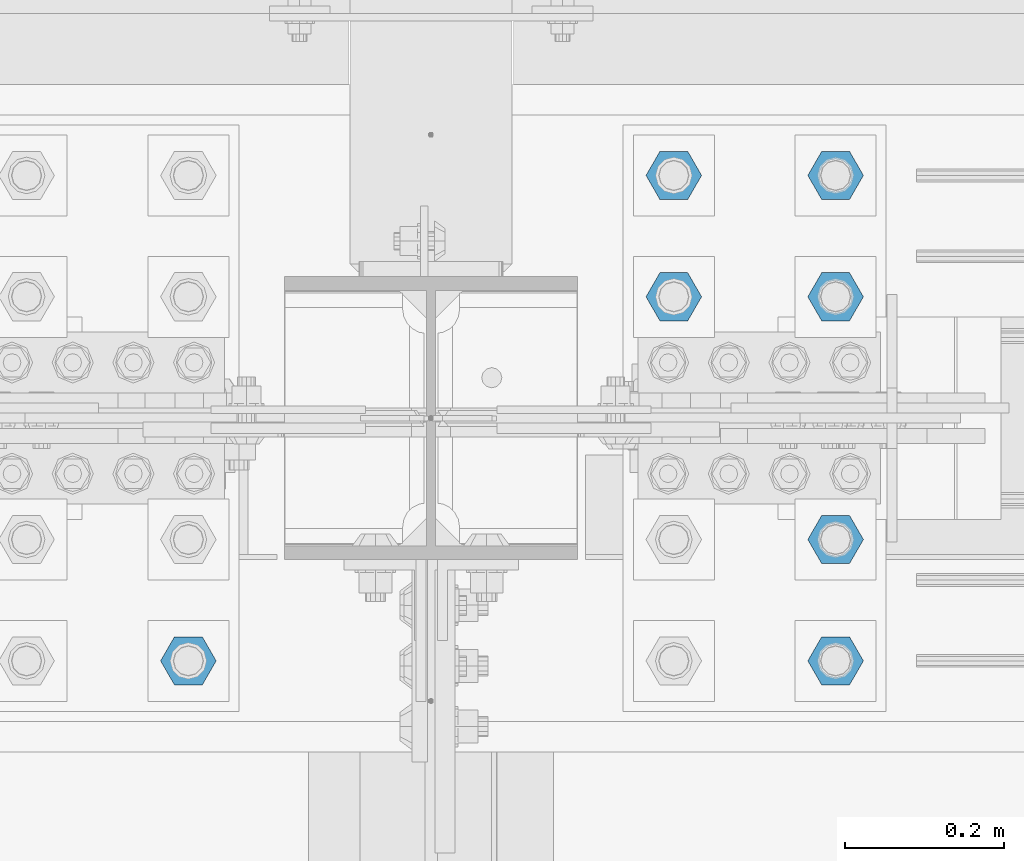
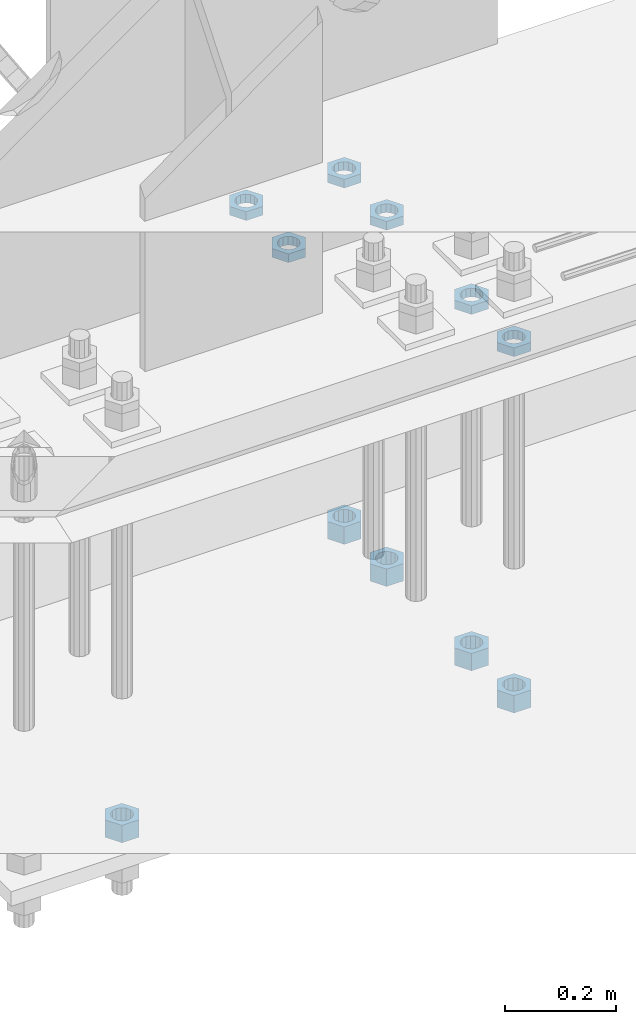
# One storey, part 2886 of 3843: 11 beams, 1 element without a shape of its own.
"""IFC2X3 building model written with IfcOpenShell, lengths in millimetres."""

from ifc_helpers import new_model, si_unit, frame, origin_with_axes, place, context, subcontext, project, spatial, faceted_brep, material, type_object, element, aggregate, save


model = new_model("IFC2X3")

# Units and contexts
model_context = context("Model", 3, precision=1e-05, world=origin_with_axes())
body_context = subcontext(model_context, "Body", "Model", "MODEL_VIEW")
ifc_project = project(units=[si_unit("LENGTHUNIT", "METRE", prefix="MILLI"), si_unit("AREAUNIT", "SQUARE_METRE"), si_unit("VOLUMEUNIT", "CUBIC_METRE"), si_unit("MASSUNIT", "GRAM", prefix="KILO"), si_unit("TIMEUNIT", "SECOND"), si_unit("PLANEANGLEUNIT", "RADIAN"), si_unit("SOLIDANGLEUNIT", "STERADIAN"), si_unit("THERMODYNAMICTEMPERATUREUNIT", "DEGREE_CELSIUS"), si_unit("LUMINOUSINTENSITYUNIT", "LUMEN")], contexts=[model_context])

# Site, building, storey
site_placement = place(None, origin_with_axes())
site = spatial("IfcSite", under=ifc_project, at=site_placement, CompositionType="ELEMENT")
building_placement = place(site_placement, origin_with_axes())
building = spatial("IfcBuilding", under=site, at=building_placement, Name="Undefined", CompositionType="ELEMENT")
storey_placement = place(building_placement, origin_with_axes())
storey = spatial("IfcBuildingStorey", under=building, at=storey_placement, Name="Undefined", CompositionType="ELEMENT", Elevation=0.0)

# Assembly, beams
assembly_placement = place(storey_placement, origin_with_axes())
assembly = element("IfcElementAssembly", 1, at=assembly_placement, inside=storey, Name="TEMPLATE", AssemblyPlace="NOTDEFINED", PredefinedType="RIGID_FRAME")
ifc_material = material(Name="STEEL/A572-50")
beam_type_1 = type_object("IfcBeamType", Name="1-1/2_HEAVY_HEX_NUT", PredefinedType="NOTDEFINED")
beam_1_placement = place(assembly_placement, frame((56438.8, 92519.5, 29298.9), z_axis=(0.0, 1.0, 0.0), x_axis=(0.0, 0.0, -1.0)))
beam_1 = element("IfcBeam", 2, at=beam_1_placement, type_object=beam_type_1, material=ifc_material, Name="NUT", ObjectType="1-1/2_HEAVY_HEX_NUT", context=body_context, shape_type="Brep", body=[
    faceted_brep([(0.0, -34.9199981689453, 0.0), (0.0, -17.4599990844727, -30.25), (38.0999999999985, -17.4599990844727, -30.25), (38.0999999999985, -34.9199981689453, 0.0), (0.0, 17.4599990844727, -30.25), (38.0999999999985, 17.4599990844727, -30.25), (0.0, 34.9199981689453, 0.0), (38.0999999999985, 34.9199981689453, 0.0), (0.0, 17.4599990844727, 30.25), (38.0999999999985, 17.4599990844727, 30.25), (0.0, -17.4599990844727, 30.25), (38.0999999999985, -17.4599990844727, 30.25), (0.0, 0.0, 20.6399993896484), (0.0, 8.9553601105581, 18.5959968835959), (38.0999999999985, 8.9553601105581, 18.5959968835959), (38.0999999999985, 0.0, 20.6399993896484), (0.0, 16.1370013209525, 12.8688291298167), (38.0999999999985, 16.1370013209525, 12.8688291298167), (0.0, 20.1225115123816, 4.59283194104501), (38.0999999999985, 20.1225115123816, 4.59283194104501), (0.0, 20.1225115123816, -4.59283194104501), (38.0999999999985, 20.1225115123816, -4.59283194104501), (0.0, 16.1370013209525, -12.8688291298167), (38.0999999999985, 16.1370013209525, -12.8688291298167), (0.0, 8.9553601105581, -18.5959968835959), (38.0999999999985, 8.9553601105581, -18.5959968835959), (0.0, 0.0, -20.6399993896484), (38.0999999999985, 0.0, -20.6399993896484), (0.0, -8.9553601105581, -18.5959968835959), (38.0999999999985, -8.9553601105581, -18.5959968835959), (0.0, -16.1370013209525, -12.8688291298167), (38.0999999999985, -16.1370013209525, -12.8688291298167), (0.0, -20.1225115123816, -4.59283194104501), (38.0999999999985, -20.1225115123816, -4.59283194104501), (0.0, -20.1225115123816, 4.59283194104501), (38.0999999999985, -20.1225115123816, 4.59283194104501), (0.0, -16.1370013209525, 12.8688291298167), (38.0999999999985, -16.1370013209525, 12.8688291298167), (0.0, -8.9553601105581, 18.5959968835959), (38.0999999999985, -8.9553601105581, 18.5959968835959)], [[[0, 1, 2, 3]], [[1, 4, 5, 2]], [[4, 6, 7, 5]], [[6, 8, 9, 7]], [[8, 10, 11, 9]], [[10, 0, 3, 11]], [[12, 13, 14, 15]], [[13, 16, 17, 14]], [[16, 18, 19, 17]], [[18, 20, 21, 19]], [[20, 22, 23, 21]], [[22, 24, 25, 23]], [[24, 26, 27, 25]], [[26, 28, 29, 27]], [[28, 30, 31, 29]], [[30, 32, 33, 31]], [[32, 34, 35, 33]], [[34, 36, 37, 35]], [[36, 38, 39, 37]], [[38, 12, 15, 39]], [[5, 7, 9, 11, 3, 2], [17, 19, 21, 23, 25, 27, 29, 31, 33, 35, 37, 39, 15, 14]], [[10, 8, 6, 4, 1, 0], [38, 36, 34, 32, 30, 28, 26, 24, 22, 20, 18, 16, 13, 12]]]),
])
beam_2_placement = place(assembly_placement, frame((56438.8, 92367.1, 29298.9), z_axis=(0.0, 1.0, 0.0), x_axis=(0.0, 0.0, -1.0)))
beam_2 = element("IfcBeam", 3, at=beam_2_placement, type_object=beam_type_1, material=ifc_material, Name="NUT", ObjectType="1-1/2_HEAVY_HEX_NUT", context=body_context, shape_type="Brep", body=[
    faceted_brep([(0.0, -34.9199981689453, 0.0), (0.0, -17.4599990844727, -30.25), (38.0999999999985, -17.4599990844727, -30.25), (38.0999999999985, -34.9199981689453, 0.0), (0.0, 17.4599990844727, -30.25), (38.0999999999985, 17.4599990844727, -30.25), (0.0, 34.9199981689453, 0.0), (38.0999999999985, 34.9199981689453, 0.0), (0.0, 17.4599990844727, 30.25), (38.0999999999985, 17.4599990844727, 30.25), (0.0, -17.4599990844727, 30.25), (38.0999999999985, -17.4599990844727, 30.25), (0.0, 0.0, 20.6399993896484), (0.0, 8.9553601105581, 18.5959968835959), (38.0999999999985, 8.9553601105581, 18.5959968835959), (38.0999999999985, 0.0, 20.6399993896484), (0.0, 16.1370013209525, 12.8688291298167), (38.0999999999985, 16.1370013209525, 12.8688291298167), (0.0, 20.1225115123816, 4.59283194104501), (38.0999999999985, 20.1225115123816, 4.59283194104501), (0.0, 20.1225115123816, -4.59283194104501), (38.0999999999985, 20.1225115123816, -4.59283194104501), (0.0, 16.1370013209525, -12.8688291298167), (38.0999999999985, 16.1370013209525, -12.8688291298167), (0.0, 8.9553601105581, -18.5959968835959), (38.0999999999985, 8.9553601105581, -18.5959968835959), (0.0, 0.0, -20.6399993896484), (38.0999999999985, 0.0, -20.6399993896484), (0.0, -8.9553601105581, -18.5959968835959), (38.0999999999985, -8.9553601105581, -18.5959968835959), (0.0, -16.1370013209525, -12.8688291298167), (38.0999999999985, -16.1370013209525, -12.8688291298167), (0.0, -20.1225115123816, -4.59283194104501), (38.0999999999985, -20.1225115123816, -4.59283194104501), (0.0, -20.1225115123816, 4.59283194104501), (38.0999999999985, -20.1225115123816, 4.59283194104501), (0.0, -16.1370013209525, 12.8688291298167), (38.0999999999985, -16.1370013209525, 12.8688291298167), (0.0, -8.9553601105581, 18.5959968835959), (38.0999999999985, -8.9553601105581, 18.5959968835959)], [[[0, 1, 2, 3]], [[1, 4, 5, 2]], [[4, 6, 7, 5]], [[6, 8, 9, 7]], [[8, 10, 11, 9]], [[10, 0, 3, 11]], [[12, 13, 14, 15]], [[13, 16, 17, 14]], [[16, 18, 19, 17]], [[18, 20, 21, 19]], [[20, 22, 23, 21]], [[22, 24, 25, 23]], [[24, 26, 27, 25]], [[26, 28, 29, 27]], [[28, 30, 31, 29]], [[30, 32, 33, 31]], [[32, 34, 35, 33]], [[34, 36, 37, 35]], [[36, 38, 39, 37]], [[38, 12, 15, 39]], [[5, 7, 9, 11, 3, 2], [17, 19, 21, 23, 25, 27, 29, 31, 33, 35, 37, 39, 15, 14]], [[10, 8, 6, 4, 1, 0], [38, 36, 34, 32, 30, 28, 26, 24, 22, 20, 18, 16, 13, 12]]]),
])
beam_3_placement = place(assembly_placement, frame((56438.8, 92062.3, 29298.9), z_axis=(0.0, 1.0, 0.0), x_axis=(0.0, 0.0, -1.0)))
beam_3 = element("IfcBeam", 4, at=beam_3_placement, type_object=beam_type_1, material=ifc_material, Name="NUT", ObjectType="1-1/2_HEAVY_HEX_NUT", context=body_context, shape_type="Brep", body=[
    faceted_brep([(0.0, -34.9199981689453, 0.0), (0.0, -17.4599990844727, -30.25), (38.0999999999985, -17.4599990844727, -30.25), (38.0999999999985, -34.9199981689453, 0.0), (0.0, 17.4599990844727, -30.25), (38.0999999999985, 17.4599990844727, -30.25), (0.0, 34.9199981689453, 0.0), (38.0999999999985, 34.9199981689453, 0.0), (0.0, 17.4599990844727, 30.25), (38.0999999999985, 17.4599990844727, 30.25), (0.0, -17.4599990844727, 30.25), (38.0999999999985, -17.4599990844727, 30.25), (0.0, 0.0, 20.6399993896484), (0.0, 8.9553601105581, 18.5959968835959), (38.0999999999985, 8.9553601105581, 18.5959968835959), (38.0999999999985, 0.0, 20.6399993896484), (0.0, 16.1370013209525, 12.8688291298167), (38.0999999999985, 16.1370013209525, 12.8688291298167), (0.0, 20.1225115123816, 4.59283194104501), (38.0999999999985, 20.1225115123816, 4.59283194104501), (0.0, 20.1225115123816, -4.59283194104501), (38.0999999999985, 20.1225115123816, -4.59283194104501), (0.0, 16.1370013209525, -12.8688291298167), (38.0999999999985, 16.1370013209525, -12.8688291298167), (0.0, 8.9553601105581, -18.5959968835959), (38.0999999999985, 8.9553601105581, -18.5959968835959), (0.0, 0.0, -20.6399993896484), (38.0999999999985, 0.0, -20.6399993896484), (0.0, -8.9553601105581, -18.5959968835959), (38.0999999999985, -8.9553601105581, -18.5959968835959), (0.0, -16.1370013209525, -12.8688291298167), (38.0999999999985, -16.1370013209525, -12.8688291298167), (0.0, -20.1225115123816, -4.59283194104501), (38.0999999999985, -20.1225115123816, -4.59283194104501), (0.0, -20.1225115123816, 4.59283194104501), (38.0999999999985, -20.1225115123816, 4.59283194104501), (0.0, -16.1370013209525, 12.8688291298167), (38.0999999999985, -16.1370013209525, 12.8688291298167), (0.0, -8.9553601105581, 18.5959968835959), (38.0999999999985, -8.9553601105581, 18.5959968835959)], [[[0, 1, 2, 3]], [[1, 4, 5, 2]], [[4, 6, 7, 5]], [[6, 8, 9, 7]], [[8, 10, 11, 9]], [[10, 0, 3, 11]], [[12, 13, 14, 15]], [[13, 16, 17, 14]], [[16, 18, 19, 17]], [[18, 20, 21, 19]], [[20, 22, 23, 21]], [[22, 24, 25, 23]], [[24, 26, 27, 25]], [[26, 28, 29, 27]], [[28, 30, 31, 29]], [[30, 32, 33, 31]], [[32, 34, 35, 33]], [[34, 36, 37, 35]], [[36, 38, 39, 37]], [[38, 12, 15, 39]], [[5, 7, 9, 11, 3, 2], [17, 19, 21, 23, 25, 27, 29, 31, 33, 35, 37, 39, 15, 14]], [[10, 8, 6, 4, 1, 0], [38, 36, 34, 32, 30, 28, 26, 24, 22, 20, 18, 16, 13, 12]]]),
])
beam_4_placement = place(assembly_placement, frame((55626.0, 91909.9, 29298.9), z_axis=(0.0, 1.0, 0.0), x_axis=(0.0, 0.0, -1.0)))
beam_4 = element("IfcBeam", 5, at=beam_4_placement, type_object=beam_type_1, material=ifc_material, Name="NUT", ObjectType="1-1/2_HEAVY_HEX_NUT", context=body_context, shape_type="Brep", body=[
    faceted_brep([(0.0, -34.9199981689453, 0.0), (0.0, -17.4599990844727, -30.25), (38.0999999999985, -17.4599990844727, -30.25), (38.0999999999985, -34.9199981689453, 0.0), (0.0, 17.4599990844727, -30.25), (38.0999999999985, 17.4599990844727, -30.25), (0.0, 34.9199981689453, 0.0), (38.0999999999985, 34.9199981689453, 0.0), (0.0, 17.4599990844727, 30.25), (38.0999999999985, 17.4599990844727, 30.25), (0.0, -17.4599990844727, 30.25), (38.0999999999985, -17.4599990844727, 30.25), (0.0, 0.0, 20.6399993896484), (0.0, 8.9553601105581, 18.5959968835959), (38.0999999999985, 8.9553601105581, 18.5959968835959), (38.0999999999985, 0.0, 20.6399993896484), (0.0, 16.1370013209525, 12.8688291298167), (38.0999999999985, 16.1370013209525, 12.8688291298167), (0.0, 20.1225115123816, 4.59283194104501), (38.0999999999985, 20.1225115123816, 4.59283194104501), (0.0, 20.1225115123816, -4.59283194104501), (38.0999999999985, 20.1225115123816, -4.59283194104501), (0.0, 16.1370013209525, -12.8688291298167), (38.0999999999985, 16.1370013209525, -12.8688291298167), (0.0, 8.9553601105581, -18.5959968835959), (38.0999999999985, 8.9553601105581, -18.5959968835959), (0.0, 0.0, -20.6399993896484), (38.0999999999985, 0.0, -20.6399993896484), (0.0, -8.9553601105581, -18.5959968835959), (38.0999999999985, -8.9553601105581, -18.5959968835959), (0.0, -16.1370013209525, -12.8688291298167), (38.0999999999985, -16.1370013209525, -12.8688291298167), (0.0, -20.1225115123816, -4.59283194104501), (38.0999999999985, -20.1225115123816, -4.59283194104501), (0.0, -20.1225115123816, 4.59283194104501), (38.0999999999985, -20.1225115123816, 4.59283194104501), (0.0, -16.1370013209525, 12.8688291298167), (38.0999999999985, -16.1370013209525, 12.8688291298167), (0.0, -8.9553601105581, 18.5959968835959), (38.0999999999985, -8.9553601105581, 18.5959968835959)], [[[0, 1, 2, 3]], [[1, 4, 5, 2]], [[4, 6, 7, 5]], [[6, 8, 9, 7]], [[8, 10, 11, 9]], [[10, 0, 3, 11]], [[12, 13, 14, 15]], [[13, 16, 17, 14]], [[16, 18, 19, 17]], [[18, 20, 21, 19]], [[20, 22, 23, 21]], [[22, 24, 25, 23]], [[24, 26, 27, 25]], [[26, 28, 29, 27]], [[28, 30, 31, 29]], [[30, 32, 33, 31]], [[32, 34, 35, 33]], [[34, 36, 37, 35]], [[36, 38, 39, 37]], [[38, 12, 15, 39]], [[5, 7, 9, 11, 3, 2], [17, 19, 21, 23, 25, 27, 29, 31, 33, 35, 37, 39, 15, 14]], [[10, 8, 6, 4, 1, 0], [38, 36, 34, 32, 30, 28, 26, 24, 22, 20, 18, 16, 13, 12]]]),
])
beam_5_placement = place(assembly_placement, frame((56438.8, 91909.9, 29298.9), z_axis=(0.0, 1.0, 0.0), x_axis=(0.0, 0.0, -1.0)))
beam_5 = element("IfcBeam", 6, at=beam_5_placement, type_object=beam_type_1, material=ifc_material, Name="NUT", ObjectType="1-1/2_HEAVY_HEX_NUT", context=body_context, shape_type="Brep", body=[
    faceted_brep([(0.0, -34.9199981689453, 0.0), (0.0, -17.4599990844727, -30.25), (38.0999999999985, -17.4599990844727, -30.25), (38.0999999999985, -34.9199981689453, 0.0), (0.0, 17.4599990844727, -30.25), (38.0999999999985, 17.4599990844727, -30.25), (0.0, 34.9199981689453, 0.0), (38.0999999999985, 34.9199981689453, 0.0), (0.0, 17.4599990844727, 30.25), (38.0999999999985, 17.4599990844727, 30.25), (0.0, -17.4599990844727, 30.25), (38.0999999999985, -17.4599990844727, 30.25), (0.0, 0.0, 20.6399993896484), (0.0, 8.9553601105581, 18.5959968835959), (38.0999999999985, 8.9553601105581, 18.5959968835959), (38.0999999999985, 0.0, 20.6399993896484), (0.0, 16.1370013209525, 12.8688291298167), (38.0999999999985, 16.1370013209525, 12.8688291298167), (0.0, 20.1225115123816, 4.59283194104501), (38.0999999999985, 20.1225115123816, 4.59283194104501), (0.0, 20.1225115123816, -4.59283194104501), (38.0999999999985, 20.1225115123816, -4.59283194104501), (0.0, 16.1370013209525, -12.8688291298167), (38.0999999999985, 16.1370013209525, -12.8688291298167), (0.0, 8.9553601105581, -18.5959968835959), (38.0999999999985, 8.9553601105581, -18.5959968835959), (0.0, 0.0, -20.6399993896484), (38.0999999999985, 0.0, -20.6399993896484), (0.0, -8.9553601105581, -18.5959968835959), (38.0999999999985, -8.9553601105581, -18.5959968835959), (0.0, -16.1370013209525, -12.8688291298167), (38.0999999999985, -16.1370013209525, -12.8688291298167), (0.0, -20.1225115123816, -4.59283194104501), (38.0999999999985, -20.1225115123816, -4.59283194104501), (0.0, -20.1225115123816, 4.59283194104501), (38.0999999999985, -20.1225115123816, 4.59283194104501), (0.0, -16.1370013209525, 12.8688291298167), (38.0999999999985, -16.1370013209525, 12.8688291298167), (0.0, -8.9553601105581, 18.5959968835959), (38.0999999999985, -8.9553601105581, 18.5959968835959)], [[[0, 1, 2, 3]], [[1, 4, 5, 2]], [[4, 6, 7, 5]], [[6, 8, 9, 7]], [[8, 10, 11, 9]], [[10, 0, 3, 11]], [[12, 13, 14, 15]], [[13, 16, 17, 14]], [[16, 18, 19, 17]], [[18, 20, 21, 19]], [[20, 22, 23, 21]], [[22, 24, 25, 23]], [[24, 26, 27, 25]], [[26, 28, 29, 27]], [[28, 30, 31, 29]], [[30, 32, 33, 31]], [[32, 34, 35, 33]], [[34, 36, 37, 35]], [[36, 38, 39, 37]], [[38, 12, 15, 39]], [[5, 7, 9, 11, 3, 2], [17, 19, 21, 23, 25, 27, 29, 31, 33, 35, 37, 39, 15, 14]], [[10, 8, 6, 4, 1, 0], [38, 36, 34, 32, 30, 28, 26, 24, 22, 20, 18, 16, 13, 12]]]),
])
beam_type_2 = type_object("IfcBeamType", Name="1-1/2_HALF_NUT", PredefinedType="NOTDEFINED")
beam_6_placement = place(assembly_placement, frame((56438.8, 92519.5, 30060.9), z_axis=(0.0, 1.0, 0.0), x_axis=(0.0, 0.0, -1.0)))
beam_6 = element("IfcBeam", 7, at=beam_6_placement, type_object=beam_type_2, material=ifc_material, Name="NUT", ObjectType="1-1/2_HALF_NUT", context=body_context, shape_type="Brep", body=[
    faceted_brep([(0.0, -34.9199981689453, 0.0), (0.0, -17.4599990844727, -30.25), (19.0500000000029, -17.4599990844727, -30.25), (19.0500000000029, -34.9199981689453, 0.0), (0.0, 17.4599990844727, -30.25), (19.0500000000029, 17.4599990844727, -30.25), (0.0, 34.9199981689453, 0.0), (19.0500000000029, 34.9199981689453, 0.0), (0.0, 17.4599990844727, 30.25), (19.0500000000029, 17.4599990844727, 30.25), (0.0, -17.4599990844727, 30.25), (19.0500000000029, -17.4599990844727, 30.25), (0.0, 0.0, 20.6399993896484), (0.0, 8.9553601105581, 18.5959968835959), (19.0500000000029, 8.95536011056538, 18.5959968835959), (19.0500000000029, 0.0, 20.6399993896484), (0.0, 16.1370013209525, 12.8688291298167), (19.0500000000029, 16.1370013209489, 12.8688291298167), (0.0, 20.1225115123816, 4.59283194104501), (19.0500000000029, 20.1225115123852, 4.59283194104501), (0.0, 20.1225115123816, -4.59283194104501), (19.0500000000029, 20.1225115123852, -4.59283194104501), (0.0, 16.1370013209525, -12.8688291298167), (19.0500000000029, 16.1370013209489, -12.8688291298167), (0.0, 8.9553601105581, -18.5959968835959), (19.0500000000029, 8.95536011056538, -18.5959968835959), (0.0, 0.0, -20.6399993896484), (19.0500000000029, 0.0, -20.6399993896484), (0.0, -8.9553601105581, -18.5959968835959), (19.0500000000029, -8.95536011056538, -18.5959968835959), (0.0, -16.1370013209525, -12.8688291298167), (19.0500000000029, -16.1370013209489, -12.8688291298167), (0.0, -20.1225115123816, -4.59283194104501), (19.0500000000029, -20.1225115123852, -4.59283194104501), (0.0, -20.1225115123816, 4.59283194104501), (19.0500000000029, -20.1225115123852, 4.59283194104501), (0.0, -16.1370013209525, 12.8688291298167), (19.0500000000029, -16.1370013209489, 12.8688291298167), (0.0, -8.9553601105581, 18.5959968835959), (19.0500000000029, -8.95536011056538, 18.5959968835959)], [[[0, 1, 2, 3]], [[1, 4, 5, 2]], [[4, 6, 7, 5]], [[6, 8, 9, 7]], [[8, 10, 11, 9]], [[10, 0, 3, 11]], [[12, 13, 14, 15]], [[13, 16, 17, 14]], [[16, 18, 19, 17]], [[18, 20, 21, 19]], [[20, 22, 23, 21]], [[22, 24, 25, 23]], [[24, 26, 27, 25]], [[26, 28, 29, 27]], [[28, 30, 31, 29]], [[30, 32, 33, 31]], [[32, 34, 35, 33]], [[34, 36, 37, 35]], [[36, 38, 39, 37]], [[38, 12, 15, 39]], [[5, 7, 9, 11, 3, 2], [17, 19, 21, 23, 25, 27, 29, 31, 33, 35, 37, 39, 15, 14]], [[10, 8, 6, 4, 1, 0], [38, 36, 34, 32, 30, 28, 26, 24, 22, 20, 18, 16, 13, 12]]]),
])
beam_7_placement = place(assembly_placement, frame((56438.8, 92367.1, 30060.9), z_axis=(0.0, 1.0, 0.0), x_axis=(0.0, 0.0, -1.0)))
beam_7 = element("IfcBeam", 8, at=beam_7_placement, type_object=beam_type_2, material=ifc_material, Name="NUT", ObjectType="1-1/2_HALF_NUT", context=body_context, shape_type="Brep", body=[
    faceted_brep([(0.0, -34.9199981689453, 0.0), (0.0, -17.4599990844727, -30.25), (19.0500000000029, -17.4599990844727, -30.25), (19.0500000000029, -34.9199981689453, 0.0), (0.0, 17.4599990844727, -30.25), (19.0500000000029, 17.4599990844727, -30.25), (0.0, 34.9199981689453, 0.0), (19.0500000000029, 34.9199981689453, 0.0), (0.0, 17.4599990844727, 30.25), (19.0500000000029, 17.4599990844727, 30.25), (0.0, -17.4599990844727, 30.25), (19.0500000000029, -17.4599990844727, 30.25), (0.0, 0.0, 20.6399993896484), (0.0, 8.9553601105581, 18.5959968835959), (19.0500000000029, 8.95536011056538, 18.5959968835959), (19.0500000000029, 0.0, 20.6399993896484), (0.0, 16.1370013209525, 12.8688291298167), (19.0500000000029, 16.1370013209489, 12.8688291298167), (0.0, 20.1225115123816, 4.59283194104501), (19.0500000000029, 20.1225115123852, 4.59283194104501), (0.0, 20.1225115123816, -4.59283194104501), (19.0500000000029, 20.1225115123852, -4.59283194104501), (0.0, 16.1370013209525, -12.8688291298167), (19.0500000000029, 16.1370013209489, -12.8688291298167), (0.0, 8.9553601105581, -18.5959968835959), (19.0500000000029, 8.95536011056538, -18.5959968835959), (0.0, 0.0, -20.6399993896484), (19.0500000000029, 0.0, -20.6399993896484), (0.0, -8.9553601105581, -18.5959968835959), (19.0500000000029, -8.95536011056538, -18.5959968835959), (0.0, -16.1370013209525, -12.8688291298167), (19.0500000000029, -16.1370013209489, -12.8688291298167), (0.0, -20.1225115123816, -4.59283194104501), (19.0500000000029, -20.1225115123852, -4.59283194104501), (0.0, -20.1225115123816, 4.59283194104501), (19.0500000000029, -20.1225115123852, 4.59283194104501), (0.0, -16.1370013209525, 12.8688291298167), (19.0500000000029, -16.1370013209489, 12.8688291298167), (0.0, -8.9553601105581, 18.5959968835959), (19.0500000000029, -8.95536011056538, 18.5959968835959)], [[[0, 1, 2, 3]], [[1, 4, 5, 2]], [[4, 6, 7, 5]], [[6, 8, 9, 7]], [[8, 10, 11, 9]], [[10, 0, 3, 11]], [[12, 13, 14, 15]], [[13, 16, 17, 14]], [[16, 18, 19, 17]], [[18, 20, 21, 19]], [[20, 22, 23, 21]], [[22, 24, 25, 23]], [[24, 26, 27, 25]], [[26, 28, 29, 27]], [[28, 30, 31, 29]], [[30, 32, 33, 31]], [[32, 34, 35, 33]], [[34, 36, 37, 35]], [[36, 38, 39, 37]], [[38, 12, 15, 39]], [[5, 7, 9, 11, 3, 2], [17, 19, 21, 23, 25, 27, 29, 31, 33, 35, 37, 39, 15, 14]], [[10, 8, 6, 4, 1, 0], [38, 36, 34, 32, 30, 28, 26, 24, 22, 20, 18, 16, 13, 12]]]),
])
beam_8_placement = place(assembly_placement, frame((56235.6, 92519.5, 30060.9), z_axis=(0.0, 1.0, 0.0), x_axis=(0.0, 0.0, -1.0)))
beam_8 = element("IfcBeam", 9, at=beam_8_placement, type_object=beam_type_2, material=ifc_material, Name="NUT", ObjectType="1-1/2_HALF_NUT", context=body_context, shape_type="Brep", body=[
    faceted_brep([(0.0, -34.9199981689453, 0.0), (0.0, -17.4599990844727, -30.25), (19.0500000000029, -17.4599990844727, -30.25), (19.0500000000029, -34.9199981689453, 0.0), (0.0, 17.4599990844727, -30.25), (19.0500000000029, 17.4599990844727, -30.25), (0.0, 34.9199981689453, 0.0), (19.0500000000029, 34.9199981689453, 0.0), (0.0, 17.4599990844727, 30.25), (19.0500000000029, 17.4599990844727, 30.25), (0.0, -17.4599990844727, 30.25), (19.0500000000029, -17.4599990844727, 30.25), (0.0, 0.0, 20.6399993896484), (0.0, 8.9553601105581, 18.5959968835959), (19.0500000000029, 8.95536011056538, 18.5959968835959), (19.0500000000029, 0.0, 20.6399993896484), (0.0, 16.1370013209525, 12.8688291298167), (19.0500000000029, 16.1370013209489, 12.8688291298167), (0.0, 20.1225115123816, 4.59283194104501), (19.0500000000029, 20.1225115123852, 4.59283194104501), (0.0, 20.1225115123816, -4.59283194104501), (19.0500000000029, 20.1225115123852, -4.59283194104501), (0.0, 16.1370013209525, -12.8688291298167), (19.0500000000029, 16.1370013209489, -12.8688291298167), (0.0, 8.9553601105581, -18.5959968835959), (19.0500000000029, 8.95536011056538, -18.5959968835959), (0.0, 0.0, -20.6399993896484), (19.0500000000029, 0.0, -20.6399993896484), (0.0, -8.9553601105581, -18.5959968835959), (19.0500000000029, -8.95536011056538, -18.5959968835959), (0.0, -16.1370013209525, -12.8688291298167), (19.0500000000029, -16.1370013209489, -12.8688291298167), (0.0, -20.1225115123816, -4.59283194104501), (19.0500000000029, -20.1225115123852, -4.59283194104501), (0.0, -20.1225115123816, 4.59283194104501), (19.0500000000029, -20.1225115123852, 4.59283194104501), (0.0, -16.1370013209525, 12.8688291298167), (19.0500000000029, -16.1370013209489, 12.8688291298167), (0.0, -8.9553601105581, 18.5959968835959), (19.0500000000029, -8.95536011056538, 18.5959968835959)], [[[0, 1, 2, 3]], [[1, 4, 5, 2]], [[4, 6, 7, 5]], [[6, 8, 9, 7]], [[8, 10, 11, 9]], [[10, 0, 3, 11]], [[12, 13, 14, 15]], [[13, 16, 17, 14]], [[16, 18, 19, 17]], [[18, 20, 21, 19]], [[20, 22, 23, 21]], [[22, 24, 25, 23]], [[24, 26, 27, 25]], [[26, 28, 29, 27]], [[28, 30, 31, 29]], [[30, 32, 33, 31]], [[32, 34, 35, 33]], [[34, 36, 37, 35]], [[36, 38, 39, 37]], [[38, 12, 15, 39]], [[5, 7, 9, 11, 3, 2], [17, 19, 21, 23, 25, 27, 29, 31, 33, 35, 37, 39, 15, 14]], [[10, 8, 6, 4, 1, 0], [38, 36, 34, 32, 30, 28, 26, 24, 22, 20, 18, 16, 13, 12]]]),
])
beam_9_placement = place(assembly_placement, frame((56235.6, 92367.1, 30060.9), z_axis=(0.0, 1.0, 0.0), x_axis=(0.0, 0.0, -1.0)))
beam_9 = element("IfcBeam", 10, at=beam_9_placement, type_object=beam_type_2, material=ifc_material, Name="NUT", ObjectType="1-1/2_HALF_NUT", context=body_context, shape_type="Brep", body=[
    faceted_brep([(0.0, -34.9199981689453, 0.0), (0.0, -17.4599990844727, -30.25), (19.0500000000029, -17.4599990844727, -30.25), (19.0500000000029, -34.9199981689453, 0.0), (0.0, 17.4599990844727, -30.25), (19.0500000000029, 17.4599990844727, -30.25), (0.0, 34.9199981689453, 0.0), (19.0500000000029, 34.9199981689453, 0.0), (0.0, 17.4599990844727, 30.25), (19.0500000000029, 17.4599990844727, 30.25), (0.0, -17.4599990844727, 30.25), (19.0500000000029, -17.4599990844727, 30.25), (0.0, 0.0, 20.6399993896484), (0.0, 8.9553601105581, 18.5959968835959), (19.0500000000029, 8.95536011056538, 18.5959968835959), (19.0500000000029, 0.0, 20.6399993896484), (0.0, 16.1370013209525, 12.8688291298167), (19.0500000000029, 16.1370013209489, 12.8688291298167), (0.0, 20.1225115123816, 4.59283194104501), (19.0500000000029, 20.1225115123852, 4.59283194104501), (0.0, 20.1225115123816, -4.59283194104501), (19.0500000000029, 20.1225115123852, -4.59283194104501), (0.0, 16.1370013209525, -12.8688291298167), (19.0500000000029, 16.1370013209489, -12.8688291298167), (0.0, 8.9553601105581, -18.5959968835959), (19.0500000000029, 8.95536011056538, -18.5959968835959), (0.0, 0.0, -20.6399993896484), (19.0500000000029, 0.0, -20.6399993896484), (0.0, -8.9553601105581, -18.5959968835959), (19.0500000000029, -8.95536011056538, -18.5959968835959), (0.0, -16.1370013209525, -12.8688291298167), (19.0500000000029, -16.1370013209489, -12.8688291298167), (0.0, -20.1225115123816, -4.59283194104501), (19.0500000000029, -20.1225115123852, -4.59283194104501), (0.0, -20.1225115123816, 4.59283194104501), (19.0500000000029, -20.1225115123852, 4.59283194104501), (0.0, -16.1370013209525, 12.8688291298167), (19.0500000000029, -16.1370013209489, 12.8688291298167), (0.0, -8.9553601105581, 18.5959968835959), (19.0500000000029, -8.95536011056538, 18.5959968835959)], [[[0, 1, 2, 3]], [[1, 4, 5, 2]], [[4, 6, 7, 5]], [[6, 8, 9, 7]], [[8, 10, 11, 9]], [[10, 0, 3, 11]], [[12, 13, 14, 15]], [[13, 16, 17, 14]], [[16, 18, 19, 17]], [[18, 20, 21, 19]], [[20, 22, 23, 21]], [[22, 24, 25, 23]], [[24, 26, 27, 25]], [[26, 28, 29, 27]], [[28, 30, 31, 29]], [[30, 32, 33, 31]], [[32, 34, 35, 33]], [[34, 36, 37, 35]], [[36, 38, 39, 37]], [[38, 12, 15, 39]], [[5, 7, 9, 11, 3, 2], [17, 19, 21, 23, 25, 27, 29, 31, 33, 35, 37, 39, 15, 14]], [[10, 8, 6, 4, 1, 0], [38, 36, 34, 32, 30, 28, 26, 24, 22, 20, 18, 16, 13, 12]]]),
])
beam_10_placement = place(assembly_placement, frame((56438.8, 92062.3, 30060.9), z_axis=(0.0, 1.0, 0.0), x_axis=(0.0, 0.0, -1.0)))
beam_10 = element("IfcBeam", 11, at=beam_10_placement, type_object=beam_type_2, material=ifc_material, Name="NUT", ObjectType="1-1/2_HALF_NUT", context=body_context, shape_type="Brep", body=[
    faceted_brep([(0.0, -34.9199981689453, 0.0), (0.0, -17.4599990844727, -30.25), (19.0500000000029, -17.4599990844727, -30.25), (19.0500000000029, -34.9199981689453, 0.0), (0.0, 17.4599990844727, -30.25), (19.0500000000029, 17.4599990844727, -30.25), (0.0, 34.9199981689453, 0.0), (19.0500000000029, 34.9199981689453, 0.0), (0.0, 17.4599990844727, 30.25), (19.0500000000029, 17.4599990844727, 30.25), (0.0, -17.4599990844727, 30.25), (19.0500000000029, -17.4599990844727, 30.25), (0.0, 0.0, 20.6399993896484), (0.0, 8.9553601105581, 18.5959968835959), (19.0500000000029, 8.95536011056538, 18.5959968835959), (19.0500000000029, 0.0, 20.6399993896484), (0.0, 16.1370013209525, 12.8688291298167), (19.0500000000029, 16.1370013209489, 12.8688291298167), (0.0, 20.1225115123816, 4.59283194104501), (19.0500000000029, 20.1225115123852, 4.59283194104501), (0.0, 20.1225115123816, -4.59283194104501), (19.0500000000029, 20.1225115123852, -4.59283194104501), (0.0, 16.1370013209525, -12.8688291298167), (19.0500000000029, 16.1370013209489, -12.8688291298167), (0.0, 8.9553601105581, -18.5959968835959), (19.0500000000029, 8.95536011056538, -18.5959968835959), (0.0, 0.0, -20.6399993896484), (19.0500000000029, 0.0, -20.6399993896484), (0.0, -8.9553601105581, -18.5959968835959), (19.0500000000029, -8.95536011056538, -18.5959968835959), (0.0, -16.1370013209525, -12.8688291298167), (19.0500000000029, -16.1370013209489, -12.8688291298167), (0.0, -20.1225115123816, -4.59283194104501), (19.0500000000029, -20.1225115123852, -4.59283194104501), (0.0, -20.1225115123816, 4.59283194104501), (19.0500000000029, -20.1225115123852, 4.59283194104501), (0.0, -16.1370013209525, 12.8688291298167), (19.0500000000029, -16.1370013209489, 12.8688291298167), (0.0, -8.9553601105581, 18.5959968835959), (19.0500000000029, -8.95536011056538, 18.5959968835959)], [[[0, 1, 2, 3]], [[1, 4, 5, 2]], [[4, 6, 7, 5]], [[6, 8, 9, 7]], [[8, 10, 11, 9]], [[10, 0, 3, 11]], [[12, 13, 14, 15]], [[13, 16, 17, 14]], [[16, 18, 19, 17]], [[18, 20, 21, 19]], [[20, 22, 23, 21]], [[22, 24, 25, 23]], [[24, 26, 27, 25]], [[26, 28, 29, 27]], [[28, 30, 31, 29]], [[30, 32, 33, 31]], [[32, 34, 35, 33]], [[34, 36, 37, 35]], [[36, 38, 39, 37]], [[38, 12, 15, 39]], [[5, 7, 9, 11, 3, 2], [17, 19, 21, 23, 25, 27, 29, 31, 33, 35, 37, 39, 15, 14]], [[10, 8, 6, 4, 1, 0], [38, 36, 34, 32, 30, 28, 26, 24, 22, 20, 18, 16, 13, 12]]]),
])
beam_11_placement = place(assembly_placement, frame((56438.8, 91909.9, 30060.9), z_axis=(0.0, 1.0, 0.0), x_axis=(0.0, 0.0, -1.0)))
beam_11 = element("IfcBeam", 12, at=beam_11_placement, type_object=beam_type_2, material=ifc_material, Name="NUT", ObjectType="1-1/2_HALF_NUT", context=body_context, shape_type="Brep", body=[
    faceted_brep([(0.0, -34.9199981689453, 0.0), (0.0, -17.4599990844727, -30.25), (19.0500000000029, -17.4599990844727, -30.25), (19.0500000000029, -34.9199981689453, 0.0), (0.0, 17.4599990844727, -30.25), (19.0500000000029, 17.4599990844727, -30.25), (0.0, 34.9199981689453, 0.0), (19.0500000000029, 34.9199981689453, 0.0), (0.0, 17.4599990844727, 30.25), (19.0500000000029, 17.4599990844727, 30.25), (0.0, -17.4599990844727, 30.25), (19.0500000000029, -17.4599990844727, 30.25), (0.0, 0.0, 20.6399993896484), (0.0, 8.9553601105581, 18.5959968835959), (19.0500000000029, 8.95536011056538, 18.5959968835959), (19.0500000000029, 0.0, 20.6399993896484), (0.0, 16.1370013209525, 12.8688291298167), (19.0500000000029, 16.1370013209489, 12.8688291298167), (0.0, 20.1225115123816, 4.59283194104501), (19.0500000000029, 20.1225115123852, 4.59283194104501), (0.0, 20.1225115123816, -4.59283194104501), (19.0500000000029, 20.1225115123852, -4.59283194104501), (0.0, 16.1370013209525, -12.8688291298167), (19.0500000000029, 16.1370013209489, -12.8688291298167), (0.0, 8.9553601105581, -18.5959968835959), (19.0500000000029, 8.95536011056538, -18.5959968835959), (0.0, 0.0, -20.6399993896484), (19.0500000000029, 0.0, -20.6399993896484), (0.0, -8.9553601105581, -18.5959968835959), (19.0500000000029, -8.95536011056538, -18.5959968835959), (0.0, -16.1370013209525, -12.8688291298167), (19.0500000000029, -16.1370013209489, -12.8688291298167), (0.0, -20.1225115123816, -4.59283194104501), (19.0500000000029, -20.1225115123852, -4.59283194104501), (0.0, -20.1225115123816, 4.59283194104501), (19.0500000000029, -20.1225115123852, 4.59283194104501), (0.0, -16.1370013209525, 12.8688291298167), (19.0500000000029, -16.1370013209489, 12.8688291298167), (0.0, -8.9553601105581, 18.5959968835959), (19.0500000000029, -8.95536011056538, 18.5959968835959)], [[[0, 1, 2, 3]], [[1, 4, 5, 2]], [[4, 6, 7, 5]], [[6, 8, 9, 7]], [[8, 10, 11, 9]], [[10, 0, 3, 11]], [[12, 13, 14, 15]], [[13, 16, 17, 14]], [[16, 18, 19, 17]], [[18, 20, 21, 19]], [[20, 22, 23, 21]], [[22, 24, 25, 23]], [[24, 26, 27, 25]], [[26, 28, 29, 27]], [[28, 30, 31, 29]], [[30, 32, 33, 31]], [[32, 34, 35, 33]], [[34, 36, 37, 35]], [[36, 38, 39, 37]], [[38, 12, 15, 39]], [[5, 7, 9, 11, 3, 2], [17, 19, 21, 23, 25, 27, 29, 31, 33, 35, 37, 39, 15, 14]], [[10, 8, 6, 4, 1, 0], [38, 36, 34, 32, 30, 28, 26, 24, 22, 20, 18, 16, 13, 12]]]),
])
aggregate(assembly, [beam_1, beam_2, beam_3, beam_4, beam_5, beam_6, beam_7, beam_8, beam_9, beam_10, beam_11])

save(model, "model.ifc")
